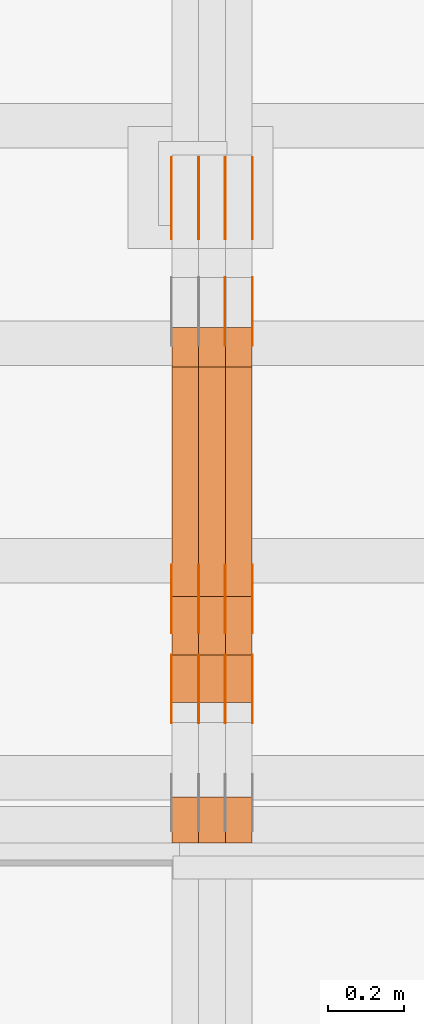
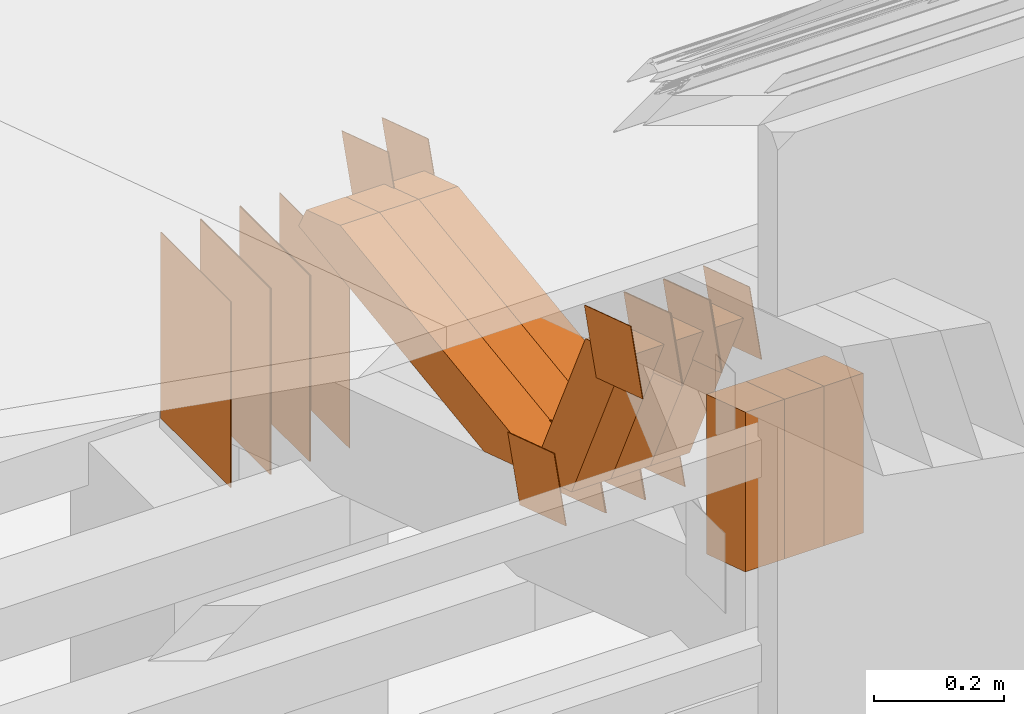
# One storey, part 300 of 385: 29 proxies.
"""IFC2X3 building model written with IfcOpenShell, lengths in millimetres."""

from ifc_helpers import new_model, entity, si_unit, converted_unit, derived_unit, direction, frame, origin, origin_2d_with_axis, place, context, subcontext, project, spatial, polyline, rectangle, outline, extrude, source, transform, mapped, material, type_object, type_shapes, element, save


model = new_model("IFC2X3")

# Units and contexts
model_context = context("Model", 3, precision=0.01, world=origin(), true_north=direction((6.12303176911189e-17, 1.0)))
body_context = subcontext(model_context, "Body", "Model", "MODEL_VIEW")
ifc_project = project(units=[si_unit("LENGTHUNIT", "METRE", prefix="MILLI"), si_unit("AREAUNIT", "SQUARE_METRE"), si_unit("VOLUMEUNIT", "CUBIC_METRE"), converted_unit("PLANEANGLEUNIT", "DEGREE", entity("IfcRatioMeasure", 0.0174532925199433), si_unit("PLANEANGLEUNIT", "RADIAN"), dimensions=[0, 0, 0, 0, 0, 0, 0]), si_unit("MASSUNIT", "GRAM", prefix="KILO"), derived_unit("MASSDENSITYUNIT", [(si_unit("MASSUNIT", "GRAM", prefix="KILO"), 1), (si_unit("LENGTHUNIT", "METRE"), -3)]), si_unit("TIMEUNIT", "SECOND"), si_unit("FREQUENCYUNIT", "HERTZ"), si_unit("THERMODYNAMICTEMPERATUREUNIT", "DEGREE_CELSIUS"), derived_unit("THERMALTRANSMITTANCEUNIT", [(si_unit("MASSUNIT", "GRAM", prefix="KILO"), 1), (si_unit("THERMODYNAMICTEMPERATUREUNIT", "KELVIN"), -1), (si_unit("TIMEUNIT", "SECOND"), -3)]), derived_unit("VOLUMETRICFLOWRATEUNIT", [(si_unit("LENGTHUNIT", "METRE"), 3), (si_unit("TIMEUNIT", "SECOND"), -1)]), si_unit("ELECTRICCURRENTUNIT", "AMPERE"), si_unit("ELECTRICVOLTAGEUNIT", "VOLT"), si_unit("POWERUNIT", "WATT"), si_unit("FORCEUNIT", "NEWTON", prefix="KILO"), si_unit("ILLUMINANCEUNIT", "LUX"), si_unit("LUMINOUSFLUXUNIT", "LUMEN"), si_unit("LUMINOUSINTENSITYUNIT", "CANDELA"), derived_unit("USERDEFINED", [(si_unit("MASSUNIT", "GRAM", prefix="KILO"), -1), (si_unit("LENGTHUNIT", "METRE"), -2), (si_unit("TIMEUNIT", "SECOND"), 3), (si_unit("LUMINOUSFLUXUNIT", "LUMEN"), 1)]), derived_unit("LINEARVELOCITYUNIT", [(si_unit("LENGTHUNIT", "METRE"), 1), (si_unit("TIMEUNIT", "SECOND"), -1)]), si_unit("PRESSUREUNIT", "PASCAL"), derived_unit("USERDEFINED", [(si_unit("LENGTHUNIT", "METRE"), -2), (si_unit("MASSUNIT", "GRAM", prefix="KILO"), 1), (si_unit("TIMEUNIT", "SECOND"), -2)])], contexts=[model_context])

# Site, building, storey
site_placement = place(None, origin())
site = spatial("IfcSite", under=ifc_project, at=site_placement, CompositionType="ELEMENT")
building_placement = place(site_placement, origin())
building = spatial("IfcBuilding", under=site, at=building_placement, CompositionType="ELEMENT")
storey_placement = place(building_placement, origin())
storey = spatial("IfcBuildingStorey", under=building, at=storey_placement, Name="Default", CompositionType="ELEMENT", Elevation=0.0)

# Proxies
ifc_material_1 = material(Name="IfcSurfaceStyle #514924")
building_element_proxy_type_1 = type_object("IfcBuildingElementProxyType", PredefinedType="NOTDEFINED", material=ifc_material_1)
shared_shape_1 = source(origin(), body_context, "Body", "SweptSolid", [
    extrude(outline(polyline([(-74.9998605591118, -59.9999264677601), (74.9998754286171, -59.9999264677601), (74.9998605591118, 59.9999264677602), (-74.9998754286171, 59.9999264677602), (-74.9998605591118, -59.9999264677601)])), frame((74.9998754286171, 60.0000503992849, 0.0), z_axis=(0.0, 0.0, 1.0), x_axis=(-1.0, 0.0, 0.0)), (0.0, 0.0, 1.0), 1.3),
])
type_shapes(building_element_proxy_type_1, [shared_shape_1])
proxy_1_placement = place(building_placement, frame((42386.3, 16352.8320303235, 3323.23212676408), z_axis=(-1.0, 0.0, 0.0), x_axis=(0.0, -0.951056516295124, 0.309016994375039)))
element("IfcBuildingElementProxy", 1, at=proxy_1_placement, inside=storey, type_object=building_element_proxy_type_1, material=ifc_material_1, context=body_context, shape_type="MappedRepresentation", body=[
    mapped(shared_shape_1, transform((0.0, 0.0, 0.0), scale=1.0)),
])
ifc_material_2 = material(Name="IfcSurfaceStyle #514867")
building_element_proxy_type_2 = type_object("IfcBuildingElementProxyType", PredefinedType="NOTDEFINED", material=ifc_material_2)
shared_shape_2 = source(origin(), body_context, "Body", "SweptSolid", [
    extrude(outline(polyline([(-74.9998605591118, -59.9999264677601), (74.9998754286171, -59.9999264677601), (74.9998605591118, 59.9999264677602), (-74.9998754286171, 59.9999264677602), (-74.9998605591118, -59.9999264677601)])), frame((74.9998754286171, 60.0000503992849, 0.0), z_axis=(0.0, 0.0, 1.0), x_axis=(-1.0, 0.0, 0.0)), (0.0, 0.0, 1.0), 1.3),
])
type_shapes(building_element_proxy_type_2, [shared_shape_2])
proxy_2_placement = place(building_placement, frame((42315.0, 16352.8320303235, 3323.23212676408), z_axis=(-1.0, 0.0, 0.0), x_axis=(0.0, -0.951056516295124, 0.309016994375039)))
element("IfcBuildingElementProxy", 2, at=proxy_2_placement, inside=storey, type_object=building_element_proxy_type_2, material=ifc_material_2, context=body_context, shape_type="MappedRepresentation", body=[
    mapped(shared_shape_2, transform((0.0, 0.0, 0.0), scale=1.0)),
])
ifc_material_3 = material(Name="IfcSurfaceStyle #514810")
building_element_proxy_type_3 = type_object("IfcBuildingElementProxyType", PredefinedType="NOTDEFINED", material=ifc_material_3)
shared_shape_3 = source(origin(), body_context, "Body", "SweptSolid", [
    extrude(outline(polyline([(-74.9998605591118, -59.9999264677601), (74.9998754286171, -59.9999264677601), (74.9998605591118, 59.9999264677602), (-74.9998754286171, 59.9999264677602), (-74.9998605591118, -59.9999264677601)])), frame((74.9998754286171, 60.0000503992849, 0.0), z_axis=(0.0, 0.0, 1.0), x_axis=(-1.0, 0.0, 0.0)), (0.0, 0.0, 1.0), 1.3),
])
type_shapes(building_element_proxy_type_3, [shared_shape_3])
proxy_3_placement = place(building_placement, frame((42316.3, 16352.8320303235, 3323.23212676408), z_axis=(-1.0, 0.0, 0.0), x_axis=(0.0, -0.951056516295124, 0.309016994375039)))
element("IfcBuildingElementProxy", 3, at=proxy_3_placement, inside=storey, type_object=building_element_proxy_type_3, material=ifc_material_3, context=body_context, shape_type="MappedRepresentation", body=[
    mapped(shared_shape_3, transform((0.0, 0.0, 0.0), scale=1.0)),
])
ifc_material_4 = material(Name="IfcSurfaceStyle #514753")
building_element_proxy_type_4 = type_object("IfcBuildingElementProxyType", PredefinedType="NOTDEFINED", material=ifc_material_4)
shared_shape_4 = source(origin(), body_context, "Body", "SweptSolid", [
    extrude(outline(polyline([(-74.9998605591118, -59.9999264677601), (74.9998754286171, -59.9999264677601), (74.9998605591118, 59.9999264677602), (-74.9998754286171, 59.9999264677602), (-74.9998605591118, -59.9999264677601)])), frame((74.9998754286171, 60.0000503992849, 0.0), z_axis=(0.0, 0.0, 1.0), x_axis=(-1.0, 0.0, 0.0)), (0.0, 0.0, 1.0), 1.29999999999999),
])
type_shapes(building_element_proxy_type_4, [shared_shape_4])
proxy_4_placement = place(building_placement, frame((42245.0, 16352.8320303235, 3323.23212676408), z_axis=(-1.0, 0.0, 0.0), x_axis=(0.0, -0.951056516295124, 0.309016994375039)))
element("IfcBuildingElementProxy", 4, at=proxy_4_placement, inside=storey, type_object=building_element_proxy_type_4, material=ifc_material_4, context=body_context, shape_type="MappedRepresentation", body=[
    mapped(shared_shape_4, transform((0.0, 0.0, 0.0), scale=1.0)),
])
ifc_material_5 = material(Name="IfcSurfaceStyle #514696")
building_element_proxy_type_5 = type_object("IfcBuildingElementProxyType", PredefinedType="NOTDEFINED", material=ifc_material_5)
shared_shape_5 = source(origin(), body_context, "Body", "SweptSolid", [
    extrude(outline(polyline([(-74.9998605591118, -59.9999264677601), (74.9998754286171, -59.9999264677601), (74.9998605591118, 59.9999264677602), (-74.9998754286171, 59.9999264677602), (-74.9998605591118, -59.9999264677601)])), frame((74.9998754286171, 60.0000503992849, 0.0), z_axis=(0.0, 0.0, 1.0), x_axis=(-1.0, 0.0, 0.0)), (0.0, 0.0, 1.0), 1.29999999999999),
])
type_shapes(building_element_proxy_type_5, [shared_shape_5])
proxy_5_placement = place(building_placement, frame((42246.3, 16352.8320303235, 3323.23212676408), z_axis=(-1.0, 0.0, 0.0), x_axis=(0.0, -0.951056516295124, 0.309016994375039)))
element("IfcBuildingElementProxy", 5, at=proxy_5_placement, inside=storey, type_object=building_element_proxy_type_5, material=ifc_material_5, context=body_context, shape_type="MappedRepresentation", body=[
    mapped(shared_shape_5, transform((0.0, 0.0, 0.0), scale=1.0)),
])
ifc_material_6 = material(Name="IfcSurfaceStyle #514639")
building_element_proxy_type_6 = type_object("IfcBuildingElementProxyType", PredefinedType="NOTDEFINED", material=ifc_material_6)
shared_shape_6 = source(origin(), body_context, "Body", "SweptSolid", [
    extrude(outline(polyline([(-74.9998605591118, -59.9999264677601), (74.9998754286171, -59.9999264677601), (74.9998605591118, 59.9999264677602), (-74.9998754286171, 59.9999264677602), (-74.9998605591118, -59.9999264677601)])), frame((74.9998754286171, 60.0000503992849, 0.0), z_axis=(0.0, 0.0, 1.0), x_axis=(-1.0, 0.0, 0.0)), (0.0, 0.0, 1.0), 1.29999999999999),
])
type_shapes(building_element_proxy_type_6, [shared_shape_6])
proxy_6_placement = place(building_placement, frame((42175.0, 16352.8320303235, 3323.23212676408), z_axis=(-1.0, 0.0, 0.0), x_axis=(0.0, -0.951056516295124, 0.309016994375039)))
element("IfcBuildingElementProxy", 6, at=proxy_6_placement, inside=storey, type_object=building_element_proxy_type_6, material=ifc_material_6, context=body_context, shape_type="MappedRepresentation", body=[
    mapped(shared_shape_6, transform((0.0, 0.0, 0.0), scale=1.0)),
])
ifc_material_7 = material(Name="IfcSurfaceStyle #512530")
building_element_proxy_type_7 = type_object("IfcBuildingElementProxyType", PredefinedType="NOTDEFINED", material=ifc_material_7)
shared_shape_7 = source(origin(), body_context, "Body", "SweptSolid", [
    extrude(rectangle(XDim=350.0, YDim=215.999999999984, at=origin_2d_with_axis()), frame((175.0, 108.0, 0.0), z_axis=(0.0, 0.0, 1.0), x_axis=(-1.0, 0.0, 0.0)), (0.0, 0.0, 1.0), 1.29999999999999),
])
type_shapes(building_element_proxy_type_7, [shared_shape_7])
proxy_7_placement = place(building_placement, frame((42386.3, 17459.2939453125, 3165.36425781251), z_axis=(-1.0, 0.0, 0.0), x_axis=(0.0, 0.0, -1.0)))
element("IfcBuildingElementProxy", 7, at=proxy_7_placement, inside=storey, type_object=building_element_proxy_type_7, material=ifc_material_7, context=body_context, shape_type="MappedRepresentation", body=[
    mapped(shared_shape_7, transform((0.0, 0.0, 0.0), scale=1.0)),
])
ifc_material_8 = material(Name="IfcSurfaceStyle #512473")
building_element_proxy_type_8 = type_object("IfcBuildingElementProxyType", PredefinedType="NOTDEFINED", material=ifc_material_8)
shared_shape_8 = source(origin(), body_context, "Body", "SweptSolid", [
    extrude(rectangle(XDim=350.0, YDim=215.999999999984, at=origin_2d_with_axis()), frame((175.0, 108.0, 0.0), z_axis=(0.0, 0.0, 1.0), x_axis=(-1.0, 0.0, 0.0)), (0.0, 0.0, 1.0), 1.29999999999999),
])
type_shapes(building_element_proxy_type_8, [shared_shape_8])
proxy_8_placement = place(building_placement, frame((42315.0, 17459.2939453125, 3165.36425781251), z_axis=(-1.0, 0.0, 0.0), x_axis=(0.0, 0.0, -1.0)))
element("IfcBuildingElementProxy", 8, at=proxy_8_placement, inside=storey, type_object=building_element_proxy_type_8, material=ifc_material_8, context=body_context, shape_type="MappedRepresentation", body=[
    mapped(shared_shape_8, transform((0.0, 0.0, 0.0), scale=1.0)),
])
ifc_material_9 = material(Name="IfcSurfaceStyle #512416")
building_element_proxy_type_9 = type_object("IfcBuildingElementProxyType", PredefinedType="NOTDEFINED", material=ifc_material_9)
shared_shape_9 = source(origin(), body_context, "Body", "SweptSolid", [
    extrude(rectangle(XDim=350.0, YDim=215.999999999984, at=origin_2d_with_axis()), frame((175.0, 108.0, 0.0), z_axis=(0.0, 0.0, 1.0), x_axis=(-1.0, 0.0, 0.0)), (0.0, 0.0, 1.0), 1.29999999999999),
])
type_shapes(building_element_proxy_type_9, [shared_shape_9])
proxy_9_placement = place(building_placement, frame((42316.3, 17459.2939453125, 3165.36425781251), z_axis=(-1.0, 0.0, 0.0), x_axis=(0.0, 0.0, -1.0)))
element("IfcBuildingElementProxy", 9, at=proxy_9_placement, inside=storey, type_object=building_element_proxy_type_9, material=ifc_material_9, context=body_context, shape_type="MappedRepresentation", body=[
    mapped(shared_shape_9, transform((0.0, 0.0, 0.0), scale=1.0)),
])
ifc_material_10 = material(Name="IfcSurfaceStyle #512359")
building_element_proxy_type_10 = type_object("IfcBuildingElementProxyType", PredefinedType="NOTDEFINED", material=ifc_material_10)
shared_shape_10 = source(origin(), body_context, "Body", "SweptSolid", [
    extrude(rectangle(XDim=350.0, YDim=215.999999999984, at=origin_2d_with_axis()), frame((175.0, 108.0, 0.0), z_axis=(0.0, 0.0, 1.0), x_axis=(-1.0, 0.0, 0.0)), (0.0, 0.0, 1.0), 1.29999999999998),
])
type_shapes(building_element_proxy_type_10, [shared_shape_10])
proxy_10_placement = place(building_placement, frame((42245.0, 17459.2939453125, 3165.36425781251), z_axis=(-1.0, 0.0, 0.0), x_axis=(0.0, 0.0, -1.0)))
element("IfcBuildingElementProxy", 10, at=proxy_10_placement, inside=storey, type_object=building_element_proxy_type_10, material=ifc_material_10, context=body_context, shape_type="MappedRepresentation", body=[
    mapped(shared_shape_10, transform((0.0, 0.0, 0.0), scale=1.0)),
])
ifc_material_11 = material(Name="IfcSurfaceStyle #512302")
building_element_proxy_type_11 = type_object("IfcBuildingElementProxyType", PredefinedType="NOTDEFINED", material=ifc_material_11)
shared_shape_11 = source(origin(), body_context, "Body", "SweptSolid", [
    extrude(rectangle(XDim=350.0, YDim=215.999999999984, at=origin_2d_with_axis()), frame((175.0, 108.0, 0.0), z_axis=(0.0, 0.0, 1.0), x_axis=(-1.0, 0.0, 0.0)), (0.0, 0.0, 1.0), 1.29999999999998),
])
type_shapes(building_element_proxy_type_11, [shared_shape_11])
proxy_11_placement = place(building_placement, frame((42246.3, 17459.2939453125, 3165.36425781251), z_axis=(-1.0, 0.0, 0.0), x_axis=(0.0, 0.0, -1.0)))
element("IfcBuildingElementProxy", 11, at=proxy_11_placement, inside=storey, type_object=building_element_proxy_type_11, material=ifc_material_11, context=body_context, shape_type="MappedRepresentation", body=[
    mapped(shared_shape_11, transform((0.0, 0.0, 0.0), scale=1.0)),
])
ifc_material_12 = material(Name="IfcSurfaceStyle #512245")
building_element_proxy_type_12 = type_object("IfcBuildingElementProxyType", PredefinedType="NOTDEFINED", material=ifc_material_12)
shared_shape_12 = source(origin(), body_context, "Body", "SweptSolid", [
    extrude(rectangle(XDim=350.0, YDim=215.999999999984, at=origin_2d_with_axis()), frame((175.0, 108.0, 0.0), z_axis=(0.0, 0.0, 1.0), x_axis=(-1.0, 0.0, 0.0)), (0.0, 0.0, 1.0), 1.29999999999998),
])
type_shapes(building_element_proxy_type_12, [shared_shape_12])
proxy_12_placement = place(building_placement, frame((42175.0, 17459.2939453125, 3165.36425781251), z_axis=(-1.0, 0.0, 0.0), x_axis=(0.0, 0.0, -1.0)))
element("IfcBuildingElementProxy", 12, at=proxy_12_placement, inside=storey, type_object=building_element_proxy_type_12, material=ifc_material_12, context=body_context, shape_type="MappedRepresentation", body=[
    mapped(shared_shape_12, transform((0.0, 0.0, 0.0), scale=1.0)),
])
ifc_material_13 = material(Name="IfcSurfaceStyle #510478")
building_element_proxy_type_13 = type_object("IfcBuildingElementProxyType", PredefinedType="NOTDEFINED", material=ifc_material_13)
shared_shape_13 = source(origin(), body_context, "Body", "SweptSolid", [
    extrude(outline(polyline([(-75.0003249421702, -60.0000773549573), (75.0003398116874, -60.0000773549573), (75.0003249421711, 60.0000773549573), (-75.0003398116883, 60.0000773549573), (-75.0003249421702, -60.0000773549573)])), frame((75.0003398116874, 60.0000773549573, 0.0), z_axis=(0.0, 0.0, 1.0), x_axis=(-1.0, 0.0, 0.0)), (0.0, 0.0, 1.0), 1.3),
])
type_shapes(building_element_proxy_type_13, [shared_shape_13])
proxy_13_placement = place(building_placement, frame((42386.3, 16117.0849050545, 3705.49074668796), z_axis=(-1.0, 0.0, 0.0), x_axis=(0.0, -0.951056516295154, 0.309016994374948)))
element("IfcBuildingElementProxy", 13, at=proxy_13_placement, inside=storey, type_object=building_element_proxy_type_13, material=ifc_material_13, context=body_context, shape_type="MappedRepresentation", body=[
    mapped(shared_shape_13, transform((0.0, 0.0, 0.0), scale=1.0)),
])
ifc_material_14 = material(Name="IfcSurfaceStyle #510421")
building_element_proxy_type_14 = type_object("IfcBuildingElementProxyType", PredefinedType="NOTDEFINED", material=ifc_material_14)
shared_shape_14 = source(origin(), body_context, "Body", "SweptSolid", [
    extrude(outline(polyline([(-75.0003249421702, -60.0000773549573), (75.0003398116874, -60.0000773549573), (75.0003249421711, 60.0000773549573), (-75.0003398116883, 60.0000773549573), (-75.0003249421702, -60.0000773549573)])), frame((75.0003398116874, 60.0000773549573, 0.0), z_axis=(0.0, 0.0, 1.0), x_axis=(-1.0, 0.0, 0.0)), (0.0, 0.0, 1.0), 1.3),
])
type_shapes(building_element_proxy_type_14, [shared_shape_14])
proxy_14_placement = place(building_placement, frame((42315.0, 16117.0849050545, 3705.49074668796), z_axis=(-1.0, 0.0, 0.0), x_axis=(0.0, -0.951056516295154, 0.309016994374948)))
element("IfcBuildingElementProxy", 14, at=proxy_14_placement, inside=storey, type_object=building_element_proxy_type_14, material=ifc_material_14, context=body_context, shape_type="MappedRepresentation", body=[
    mapped(shared_shape_14, transform((0.0, 0.0, 0.0), scale=1.0)),
])
ifc_material_15 = material(Name="IfcSurfaceStyle #510364")
building_element_proxy_type_15 = type_object("IfcBuildingElementProxyType", PredefinedType="NOTDEFINED", material=ifc_material_15)
shared_shape_15 = source(origin(), body_context, "Body", "SweptSolid", [
    extrude(outline(polyline([(-75.0003249421702, -60.0000773549573), (75.0003398116874, -60.0000773549573), (75.0003249421711, 60.0000773549573), (-75.0003398116883, 60.0000773549573), (-75.0003249421702, -60.0000773549573)])), frame((75.0003398116874, 60.0000773549573, 0.0), z_axis=(0.0, 0.0, 1.0), x_axis=(-1.0, 0.0, 0.0)), (0.0, 0.0, 1.0), 1.3),
])
type_shapes(building_element_proxy_type_15, [shared_shape_15])
proxy_15_placement = place(building_placement, frame((42316.3, 16117.0849050545, 3705.49074668796), z_axis=(-1.0, 0.0, 0.0), x_axis=(0.0, -0.951056516295154, 0.309016994374948)))
element("IfcBuildingElementProxy", 15, at=proxy_15_placement, inside=storey, type_object=building_element_proxy_type_15, material=ifc_material_15, context=body_context, shape_type="MappedRepresentation", body=[
    mapped(shared_shape_15, transform((0.0, 0.0, 0.0), scale=1.0)),
])
ifc_material_16 = material(Name="IfcSurfaceStyle #510307")
building_element_proxy_type_16 = type_object("IfcBuildingElementProxyType", PredefinedType="NOTDEFINED", material=ifc_material_16)
shared_shape_16 = source(origin(), body_context, "Body", "SweptSolid", [
    extrude(outline(polyline([(-75.0003249421702, -60.0000773549573), (75.0003398116874, -60.0000773549573), (75.0003249421711, 60.0000773549573), (-75.0003398116883, 60.0000773549573), (-75.0003249421702, -60.0000773549573)])), frame((75.0003398116874, 60.0000773549573, 0.0), z_axis=(0.0, 0.0, 1.0), x_axis=(-1.0, 0.0, 0.0)), (0.0, 0.0, 1.0), 1.29999999999999),
])
type_shapes(building_element_proxy_type_16, [shared_shape_16])
proxy_16_placement = place(building_placement, frame((42245.0, 16117.0849050545, 3705.49074668796), z_axis=(-1.0, 0.0, 0.0), x_axis=(0.0, -0.951056516295154, 0.309016994374948)))
element("IfcBuildingElementProxy", 16, at=proxy_16_placement, inside=storey, type_object=building_element_proxy_type_16, material=ifc_material_16, context=body_context, shape_type="MappedRepresentation", body=[
    mapped(shared_shape_16, transform((0.0, 0.0, 0.0), scale=1.0)),
])
ifc_material_17 = material(Name="IfcSurfaceStyle #510250")
building_element_proxy_type_17 = type_object("IfcBuildingElementProxyType", PredefinedType="NOTDEFINED", material=ifc_material_17)
shared_shape_17 = source(origin(), body_context, "Body", "SweptSolid", [
    extrude(outline(polyline([(-75.0003249421702, -60.0000773549573), (75.0003398116874, -60.0000773549573), (75.0003249421711, 60.0000773549573), (-75.0003398116883, 60.0000773549573), (-75.0003249421702, -60.0000773549573)])), frame((75.0003398116874, 60.0000773549573, 0.0), z_axis=(0.0, 0.0, 1.0), x_axis=(-1.0, 0.0, 0.0)), (0.0, 0.0, 1.0), 1.29999999999999),
])
type_shapes(building_element_proxy_type_17, [shared_shape_17])
proxy_17_placement = place(building_placement, frame((42246.3, 16117.0849050545, 3705.49074668796), z_axis=(-1.0, 0.0, 0.0), x_axis=(0.0, -0.951056516295154, 0.309016994374948)))
element("IfcBuildingElementProxy", 17, at=proxy_17_placement, inside=storey, type_object=building_element_proxy_type_17, material=ifc_material_17, context=body_context, shape_type="MappedRepresentation", body=[
    mapped(shared_shape_17, transform((0.0, 0.0, 0.0), scale=1.0)),
])
ifc_material_18 = material(Name="IfcSurfaceStyle #510193")
building_element_proxy_type_18 = type_object("IfcBuildingElementProxyType", PredefinedType="NOTDEFINED", material=ifc_material_18)
shared_shape_18 = source(origin(), body_context, "Body", "SweptSolid", [
    extrude(outline(polyline([(-75.0003249421702, -60.0000773549573), (75.0003398116874, -60.0000773549573), (75.0003249421711, 60.0000773549573), (-75.0003398116883, 60.0000773549573), (-75.0003249421702, -60.0000773549573)])), frame((75.0003398116874, 60.0000773549573, 0.0), z_axis=(0.0, 0.0, 1.0), x_axis=(-1.0, 0.0, 0.0)), (0.0, 0.0, 1.0), 1.29999999999999),
])
type_shapes(building_element_proxy_type_18, [shared_shape_18])
proxy_18_placement = place(building_placement, frame((42175.0, 16117.0849050545, 3705.49074668796), z_axis=(-1.0, 0.0, 0.0), x_axis=(0.0, -0.951056516295154, 0.309016994374948)))
element("IfcBuildingElementProxy", 18, at=proxy_18_placement, inside=storey, type_object=building_element_proxy_type_18, material=ifc_material_18, context=body_context, shape_type="MappedRepresentation", body=[
    mapped(shared_shape_18, transform((0.0, 0.0, 0.0), scale=1.0)),
])
ifc_material_19 = material(Name="IfcSurfaceStyle #509110")
building_element_proxy_type_19 = type_object("IfcBuildingElementProxyType", PredefinedType="NOTDEFINED", material=ifc_material_19)
shared_shape_19 = source(origin(), body_context, "Body", "SweptSolid", [
    extrude(outline(polyline([(-74.9998605591058, -59.9999264677524), (74.999875428623, -59.9999264677524), (74.9998605591068, 59.9999264677524), (-74.9998754286239, 59.9999264677524), (-74.9998605591058, -59.9999264677524)])), frame((75.0002460484325, 60.0000016373508, 0.0), z_axis=(0.0, 0.0, 1.0), x_axis=(-1.0, 0.0, 0.0)), (0.0, 0.0, 1.0), 1.3),
])
type_shapes(building_element_proxy_type_19, [shared_shape_19])
proxy_19_placement = place(building_placement, frame((42386.3, 17107.0599369346, 3383.82825001787), z_axis=(-1.0, 0.0, 0.0), x_axis=(0.0, -0.951056516295154, 0.309016994374948)))
element("IfcBuildingElementProxy", 19, at=proxy_19_placement, inside=storey, type_object=building_element_proxy_type_19, material=ifc_material_19, context=body_context, shape_type="MappedRepresentation", body=[
    mapped(shared_shape_19, transform((0.0, 0.0, 0.0), scale=1.0)),
])
ifc_material_20 = material(Name="IfcSurfaceStyle #509053")
building_element_proxy_type_20 = type_object("IfcBuildingElementProxyType", PredefinedType="NOTDEFINED", material=ifc_material_20)
shared_shape_20 = source(origin(), body_context, "Body", "SweptSolid", [
    extrude(outline(polyline([(-74.9998605591058, -59.9999264677524), (74.999875428623, -59.9999264677524), (74.9998605591068, 59.9999264677524), (-74.9998754286239, 59.9999264677524), (-74.9998605591058, -59.9999264677524)])), frame((75.0002460484325, 60.0000016373508, 0.0), z_axis=(0.0, 0.0, 1.0), x_axis=(-1.0, 0.0, 0.0)), (0.0, 0.0, 1.0), 1.3),
])
type_shapes(building_element_proxy_type_20, [shared_shape_20])
proxy_20_placement = place(building_placement, frame((42315.0, 17107.0599369346, 3383.82825001787), z_axis=(-1.0, 0.0, 0.0), x_axis=(0.0, -0.951056516295154, 0.309016994374948)))
element("IfcBuildingElementProxy", 20, at=proxy_20_placement, inside=storey, type_object=building_element_proxy_type_20, material=ifc_material_20, context=body_context, shape_type="MappedRepresentation", body=[
    mapped(shared_shape_20, transform((0.0, 0.0, 0.0), scale=1.0)),
])
ifc_material_21 = material(Name="IfcSurfaceStyle #500029")
building_element_proxy_type_21 = type_object("IfcBuildingElementProxyType", Name="T1-W2 500027", PredefinedType="NOTDEFINED", material=ifc_material_21)
shared_shape_21 = source(origin(), body_context, "Body", "SweptSolid", [
    extrude(outline(polyline([(-130.705993652344, -60.0), (169.696350097656, -60.0), (130.706115722656, 60.0), (-169.696472167969, 60.0), (-130.705993652344, -60.0)])), frame((169.696429629256, 60.0, 0.0), z_axis=(0.0, 0.0, 1.0), x_axis=(-1.0, 0.0, 0.0)), (0.0, 0.0, 1.0), 70.0),
])
type_shapes(building_element_proxy_type_21, [shared_shape_21])
proxy_21_placement = place(building_placement, frame((42385.0, 15660.0, 3577.70158062465), z_axis=(-1.0, 0.0, 0.0), x_axis=(0.0, 0.0, 1.0)))
element("IfcBuildingElementProxy", 21, at=proxy_21_placement, inside=storey, type_object=building_element_proxy_type_21, material=ifc_material_21, Name="T1-W2", context=body_context, shape_type="MappedRepresentation", body=[
    mapped(shared_shape_21, transform((0.0, 0.0, 0.0), scale=1.0)),
])
ifc_material_22 = material(Name="IfcSurfaceStyle #499972")
building_element_proxy_type_22 = type_object("IfcBuildingElementProxyType", Name="T1-W2 499970", PredefinedType="NOTDEFINED", material=ifc_material_22)
shared_shape_22 = source(origin(), body_context, "Body", "SweptSolid", [
    extrude(outline(polyline([(-130.705993652344, -60.0), (169.696350097656, -60.0), (130.706115722656, 60.0), (-169.696472167969, 60.0), (-130.705993652344, -60.0)])), frame((169.696429629256, 60.0, 0.0), z_axis=(0.0, 0.0, 1.0), x_axis=(-1.0, 0.0, 0.0)), (0.0, 0.0, 1.0), 70.0),
])
type_shapes(building_element_proxy_type_22, [shared_shape_22])
proxy_22_placement = place(building_placement, frame((42315.0, 15660.0, 3577.70158062465), z_axis=(-1.0, 0.0, 0.0), x_axis=(0.0, 0.0, 1.0)))
element("IfcBuildingElementProxy", 22, at=proxy_22_placement, inside=storey, type_object=building_element_proxy_type_22, material=ifc_material_22, Name="T1-W2", context=body_context, shape_type="MappedRepresentation", body=[
    mapped(shared_shape_22, transform((0.0, 0.0, 0.0), scale=1.0)),
])
ifc_material_23 = material(Name="IfcSurfaceStyle #499915")
building_element_proxy_type_23 = type_object("IfcBuildingElementProxyType", Name="T1-W2 499913", PredefinedType="NOTDEFINED", material=ifc_material_23)
shared_shape_23 = source(origin(), body_context, "Body", "SweptSolid", [
    extrude(outline(polyline([(-130.705993652344, -60.0), (169.696350097656, -60.0), (130.706115722656, 60.0), (-169.696472167969, 60.0), (-130.705993652344, -60.0)])), frame((169.696429629256, 60.0, 0.0), z_axis=(0.0, 0.0, 1.0), x_axis=(-1.0, 0.0, 0.0)), (0.0, 0.0, 1.0), 70.0),
])
type_shapes(building_element_proxy_type_23, [shared_shape_23])
proxy_23_placement = place(building_placement, frame((42245.0, 15660.0, 3577.70158062465), z_axis=(-1.0, 0.0, 0.0), x_axis=(0.0, 0.0, 1.0)))
element("IfcBuildingElementProxy", 23, at=proxy_23_placement, inside=storey, type_object=building_element_proxy_type_23, material=ifc_material_23, Name="T1-W2", context=body_context, shape_type="MappedRepresentation", body=[
    mapped(shared_shape_23, transform((0.0, 0.0, 0.0), scale=1.0)),
])
ifc_material_24 = material(Name="IfcSurfaceStyle #499858")
building_element_proxy_type_24 = type_object("IfcBuildingElementProxyType", Name="T1-W44 499856", PredefinedType="NOTDEFINED", material=ifc_material_24)
shared_shape_24 = source(origin(), body_context, "Body", "SweptSolid", [
    extrude(outline(polyline([(-184.551057772692, -47.4997984945814), (177.527112951531, -47.4997984945814), (162.630077773546, -0.000452497529500495), (118.068221667048, 47.5000247433462), (-273.674354619433, 47.5000247433462), (-184.551057772692, -47.4997984945814)])), frame((177.527112951531, 47.5002721629815, 0.0), z_axis=(0.0, 0.0, 1.0), x_axis=(-1.0, 0.0, 0.0)), (0.0, 0.0, 1.0), 70.0),
])
type_shapes(building_element_proxy_type_24, [shared_shape_24])
proxy_24_placement = place(building_placement, frame((42385.0, 16220.4899216004, 3388.98238154171), z_axis=(-1.0, 0.0, 0.0), x_axis=(0.0, -0.425335045192995, 0.905035965766374)))
element("IfcBuildingElementProxy", 24, at=proxy_24_placement, inside=storey, type_object=building_element_proxy_type_24, material=ifc_material_24, Name="T1-W44", context=body_context, shape_type="MappedRepresentation", body=[
    mapped(shared_shape_24, transform((0.0, 0.0, 0.0), scale=1.0)),
])
ifc_material_25 = material(Name="IfcSurfaceStyle #499792")
building_element_proxy_type_25 = type_object("IfcBuildingElementProxyType", Name="T1-W44 499790", PredefinedType="NOTDEFINED", material=ifc_material_25)
shared_shape_25 = source(origin(), body_context, "Body", "SweptSolid", [
    extrude(outline(polyline([(-184.551057772692, -47.4997984945814), (177.527112951531, -47.4997984945814), (162.630077773546, -0.000452497529500495), (118.068221667048, 47.5000247433462), (-273.674354619433, 47.5000247433462), (-184.551057772692, -47.4997984945814)])), frame((177.527112951531, 47.5002721629815, 0.0), z_axis=(0.0, 0.0, 1.0), x_axis=(-1.0, 0.0, 0.0)), (0.0, 0.0, 1.0), 70.0),
])
type_shapes(building_element_proxy_type_25, [shared_shape_25])
proxy_25_placement = place(building_placement, frame((42315.0, 16220.4899216004, 3388.98238154171), z_axis=(-1.0, 0.0, 0.0), x_axis=(0.0, -0.425335045192995, 0.905035965766374)))
element("IfcBuildingElementProxy", 25, at=proxy_25_placement, inside=storey, type_object=building_element_proxy_type_25, material=ifc_material_25, Name="T1-W44", context=body_context, shape_type="MappedRepresentation", body=[
    mapped(shared_shape_25, transform((0.0, 0.0, 0.0), scale=1.0)),
])
ifc_material_26 = material(Name="IfcSurfaceStyle #499726")
building_element_proxy_type_26 = type_object("IfcBuildingElementProxyType", Name="T1-W44 499724", PredefinedType="NOTDEFINED", material=ifc_material_26)
shared_shape_26 = source(origin(), body_context, "Body", "SweptSolid", [
    extrude(outline(polyline([(-184.551057772692, -47.4997984945814), (177.527112951531, -47.4997984945814), (162.630077773546, -0.000452497529500495), (118.068221667048, 47.5000247433462), (-273.674354619433, 47.5000247433462), (-184.551057772692, -47.4997984945814)])), frame((177.527112951531, 47.5002721629815, 0.0), z_axis=(0.0, 0.0, 1.0), x_axis=(-1.0, 0.0, 0.0)), (0.0, 0.0, 1.0), 70.0),
])
type_shapes(building_element_proxy_type_26, [shared_shape_26])
proxy_26_placement = place(building_placement, frame((42245.0, 16220.4899216004, 3388.98238154171), z_axis=(-1.0, 0.0, 0.0), x_axis=(0.0, -0.425335045192995, 0.905035965766374)))
element("IfcBuildingElementProxy", 26, at=proxy_26_placement, inside=storey, type_object=building_element_proxy_type_26, material=ifc_material_26, Name="T1-W44", context=body_context, shape_type="MappedRepresentation", body=[
    mapped(shared_shape_26, transform((0.0, 0.0, 0.0), scale=1.0)),
])
ifc_material_27 = material(Name="IfcSurfaceStyle #499462")
building_element_proxy_type_27 = type_object("IfcBuildingElementProxyType", Name="T1-W8 499460", PredefinedType="NOTDEFINED", material=ifc_material_27)
shared_shape_27 = source(origin(), body_context, "Body", "SweptSolid", [
    extrude(outline(polyline([(-476.725263324644, -47.5001051695965), (180.672765845439, -47.5001051695965), (279.11020091716, -1.03605560390907e-06), (296.793624402619, 47.5001056876243), (-279.851327840575, 47.5001056876243), (-476.725263324644, -47.5001051695965)])), frame((296.793624402619, 47.5001056876243, 0.0), z_axis=(0.0, 0.0, 1.0), x_axis=(-1.0, 0.0, 0.0)), (0.0, 0.0, 1.0), 70.0),
])
type_shapes(building_element_proxy_type_27, [shared_shape_27])
proxy_27_placement = place(building_placement, frame((42385.0, 17036.40625, 3432.97192382813), z_axis=(-1.0, 0.0, 0.0), x_axis=(0.0, -0.990844046556832, -0.135011389900564)))
element("IfcBuildingElementProxy", 27, at=proxy_27_placement, inside=storey, type_object=building_element_proxy_type_27, material=ifc_material_27, Name="T1-W8", context=body_context, shape_type="MappedRepresentation", body=[
    mapped(shared_shape_27, transform((0.0, 0.0, 0.0), scale=1.0)),
])
ifc_material_28 = material(Name="IfcSurfaceStyle #499396")
building_element_proxy_type_28 = type_object("IfcBuildingElementProxyType", Name="T1-W8 499394", PredefinedType="NOTDEFINED", material=ifc_material_28)
shared_shape_28 = source(origin(), body_context, "Body", "SweptSolid", [
    extrude(outline(polyline([(-476.725263324644, -47.5001051695965), (180.672765845439, -47.5001051695965), (279.11020091716, -1.03605560390907e-06), (296.793624402619, 47.5001056876243), (-279.851327840575, 47.5001056876243), (-476.725263324644, -47.5001051695965)])), frame((296.793624402619, 47.5001056876243, 0.0), z_axis=(0.0, 0.0, 1.0), x_axis=(-1.0, 0.0, 0.0)), (0.0, 0.0, 1.0), 70.0),
])
type_shapes(building_element_proxy_type_28, [shared_shape_28])
proxy_28_placement = place(building_placement, frame((42315.0, 17036.40625, 3432.97192382813), z_axis=(-1.0, 0.0, 0.0), x_axis=(0.0, -0.990844046556832, -0.135011389900564)))
element("IfcBuildingElementProxy", 28, at=proxy_28_placement, inside=storey, type_object=building_element_proxy_type_28, material=ifc_material_28, Name="T1-W8", context=body_context, shape_type="MappedRepresentation", body=[
    mapped(shared_shape_28, transform((0.0, 0.0, 0.0), scale=1.0)),
])
ifc_material_29 = material(Name="IfcSurfaceStyle #499330")
building_element_proxy_type_29 = type_object("IfcBuildingElementProxyType", Name="T1-W8 499328", PredefinedType="NOTDEFINED", material=ifc_material_29)
shared_shape_29 = source(origin(), body_context, "Body", "SweptSolid", [
    extrude(outline(polyline([(-476.725263324644, -47.5001051695965), (180.672765845439, -47.5001051695965), (279.11020091716, -1.03605560390907e-06), (296.793624402619, 47.5001056876243), (-279.851327840575, 47.5001056876243), (-476.725263324644, -47.5001051695965)])), frame((296.793624402619, 47.5001056876243, 0.0), z_axis=(0.0, 0.0, 1.0), x_axis=(-1.0, 0.0, 0.0)), (0.0, 0.0, 1.0), 70.0),
])
type_shapes(building_element_proxy_type_29, [shared_shape_29])
proxy_29_placement = place(building_placement, frame((42245.0, 17036.40625, 3432.97192382813), z_axis=(-1.0, 0.0, 0.0), x_axis=(0.0, -0.990844046556832, -0.135011389900564)))
element("IfcBuildingElementProxy", 29, at=proxy_29_placement, inside=storey, type_object=building_element_proxy_type_29, material=ifc_material_29, Name="T1-W8", context=body_context, shape_type="MappedRepresentation", body=[
    mapped(shared_shape_29, transform((0.0, 0.0, 0.0), scale=1.0)),
])

save(model, "model.ifc")
